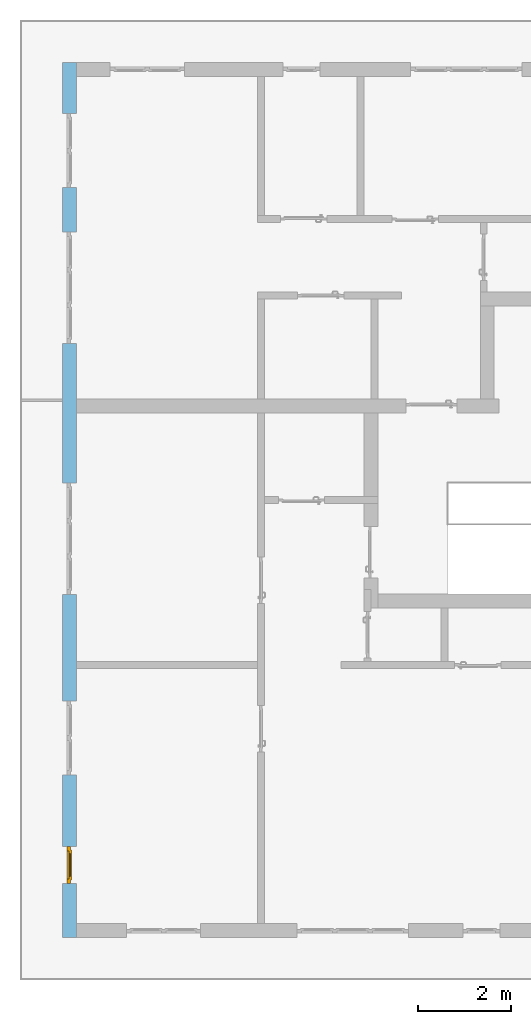
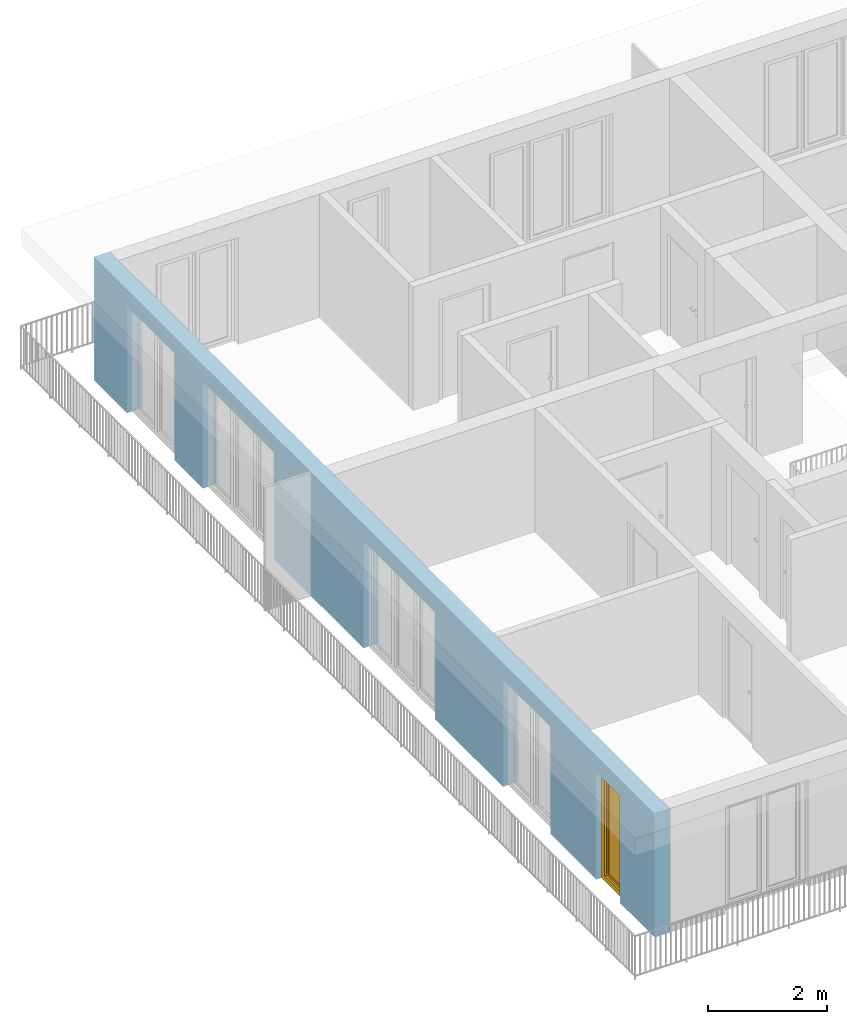
# One storey, part 12 of 54: 1 window, 5 openings, plus 1 element that does not belong to this part.
"""IFC4 building model written with IfcOpenShell, lengths in metres."""

import ifcopenshell
import ifcopenshell.guid

model = None  # the IFC model being written
_history = None  # IfcOwnerHistory: only IFC2X3 demands one
_inside = {}  # id of a spatial element -> (the spatial element, [elements in it])
_under = {}  # id of a project, library or spatial element -> (it, [spatial elements below it])
_declared = {}  # id of a project -> (the project, [libraries it declares])
_typed = {}  # id of a type object -> (the type object, [elements of that type])
_made_of = {}  # id of a material, layer set ... -> (it, [elements and type objects made of it])


def new_model(schema):
    """Start an empty IFC model of exactly this schema.

    Asked for "IFC4X3", IfcOpenShell would pick the latest addendum, in which some entities
    have other attributes; the version numbers below select the first issue.
    IFC2X3 requires an IfcOwnerHistory on every rooted entity: one is made here for all.
    """
    global model, _history
    if schema == "IFC4X3":
        model = ifcopenshell.file(schema_version=(4, 3, 0, 0))
    else:
        model = ifcopenshell.file(schema=schema)
    _inside.clear()
    _under.clear()
    _declared.clear()
    _typed.clear()
    _made_of.clear()
    _history = None
    if model.schema == "IFC2X3":
        org = make("IfcOrganization", Name="unknown")
        user = make(
            "IfcPersonAndOrganization",
            ThePerson=make("IfcPerson", FamilyName="unknown"),
            TheOrganization=org,
        )
        app = make(
            "IfcApplication",
            ApplicationDeveloper=org,
            Version="unknown",
            ApplicationFullName="unknown",
            ApplicationIdentifier="unknown",
        )
        _history = make(
            "IfcOwnerHistory",
            OwningUser=user,
            OwningApplication=app,
            ChangeAction="ADDED",
            CreationDate=0,
        )
    return model


def make(cls, **values):
    """One entity of the class cls with the attributes given. An attribute that is None is left unset."""
    return model.create_entity(
        cls, **{name: value for name, value in values.items() if value is not None}
    )


def entity(cls, *values):
    """Any entity or typed value of the class cls, its attributes in the order of the schema. None: left unset."""
    e = model.create_entity(cls)
    for i, value in enumerate(values):
        if value is not None:
            e[i] = value
    return e


def rooted(cls, **values):
    """An entity with a GlobalId (a new one), such as an element, a storey or a relation."""
    return make(cls, GlobalId=ifcopenshell.guid.new(), OwnerHistory=_history, **values)


def si_unit(unit_type, name, prefix=None):
    """IfcSIUnit, for example si_unit("LENGTHUNIT", "METRE", prefix="MILLI")."""
    return make("IfcSIUnit", UnitType=unit_type, Prefix=prefix, Name=name)


def converted_unit(unit_type, name, factor, base, dimensions=None, offset=None):
    """IfcConversionBasedUnit, such as the inch: factor (a typed value) times the base unit."""
    return make(
        "IfcConversionBasedUnit"
        if offset is None
        else "IfcConversionBasedUnitWithOffset",
        ConversionOffset=offset,
        Dimensions=None
        if dimensions is None
        else entity("IfcDimensionalExponents", *dimensions),
        UnitType=unit_type,
        Name=name,
        ConversionFactor=make(
            "IfcMeasureWithUnit", ValueComponent=factor, UnitComponent=base
        ),
    )


def derived_unit(unit_type, elements):
    """IfcDerivedUnit: a product of units, each with its exponent."""
    return make(
        "IfcDerivedUnit",
        Elements=[
            make("IfcDerivedUnitElement", Unit=unit, Exponent=power)
            for unit, power in elements
        ],
        UnitType=unit_type,
    )


def assignment(units):
    """IfcUnitAssignment: the units of a project."""
    return None if units is None else make("IfcUnitAssignment", Units=units)


def point(xyz):
    """IfcCartesianPoint."""
    return None if xyz is None else make("IfcCartesianPoint", Coordinates=xyz)


def direction(xyz):
    """IfcDirection."""
    return None if xyz is None else make("IfcDirection", DirectionRatios=xyz)


def frame(location, z_axis=None, x_axis=None):
    """IfcAxis2Placement3D, a coordinate frame: its origin and axes. An axis left out is left unset."""
    return make(
        "IfcAxis2Placement3D",
        Location=point(location),
        Axis=direction(z_axis),
        RefDirection=direction(x_axis),
    )


def origin_with_axes():
    """The frame at (0, 0, 0) with the z axis (0, 0, 1) and the x axis (1, 0, 0) written out."""
    return frame((0.0, 0.0, 0.0), z_axis=(0.0, 0.0, 1.0), x_axis=(1.0, 0.0, 0.0))


def place(relative_to, where):
    """IfcLocalPlacement: puts the frame where relative to a parent placement (None: the world)."""
    return make(
        "IfcLocalPlacement", PlacementRelTo=relative_to, RelativePlacement=where
    )


def context(
    kind, dimensions, precision=None, world=None, true_north=None, identifier=None
):
    """IfcGeometricRepresentationContext, for example the 3D "Model" context."""
    return make(
        "IfcGeometricRepresentationContext",
        ContextIdentifier=identifier,
        ContextType=kind,
        CoordinateSpaceDimension=dimensions,
        Precision=precision,
        WorldCoordinateSystem=world,
        TrueNorth=true_north,
    )


def subcontext(parent, identifier, kind, view, scale=None):
    """IfcGeometricRepresentationSubContext, for example "Body" below "Model"."""
    return make(
        "IfcGeometricRepresentationSubContext",
        ContextIdentifier=identifier,
        ContextType=kind,
        ParentContext=parent,
        TargetScale=scale,
        TargetView=view,
    )


def project(units=None, contexts=None):
    """IfcProject with its units and contexts."""
    return rooted(
        "IfcProject",
        Name="project",
        RepresentationContexts=contexts,
        UnitsInContext=assignment(units),
    )


def spatial(cls, under=None, at=None, **own):
    """A site, building, storey or space (cls), placed at a placement, below another one or the project."""
    s = rooted(cls, ObjectPlacement=at, **own)
    if under is not None:
        _under.setdefault(under.id(), (under, []))[1].append(s)
    return s


def point_list(points):
    """IfcCartesianPointList2D or 3D."""
    cls = (
        "IfcCartesianPointList2D" if len(points[0]) == 2 else "IfcCartesianPointList3D"
    )
    return make(cls, CoordList=points)


def polygons(points, faces, closed=None, point_numbers=None):
    """IfcPolygonalFaceSet: a face is its outer loop, then its inner loops; points numbered from 1."""
    made = []
    for loops in faces:
        if len(loops) == 1:
            made.append(make("IfcIndexedPolygonalFace", CoordIndex=loops[0]))
        else:
            made.append(
                make(
                    "IfcIndexedPolygonalFaceWithVoids",
                    CoordIndex=loops[0],
                    InnerCoordIndices=loops[1:],
                )
            )
    return make(
        "IfcPolygonalFaceSet",
        Coordinates=point_list(points),
        Closed=closed,
        Faces=made,
        PnIndex=point_numbers,
    )


def shape(context_of_items, identifier, shape_type, items):
    """IfcShapeRepresentation: the items that make up one representation, for example the "Body"."""
    return make(
        "IfcShapeRepresentation",
        ContextOfItems=context_of_items,
        RepresentationIdentifier=identifier,
        RepresentationType=shape_type,
        Items=items,
    )


def source(mapping_origin, context_of_items, identifier, shape_type, items):
    """IfcRepresentationMap: a shape defined once, which mapped items show again and again."""
    return make(
        "IfcRepresentationMap",
        MappingOrigin=mapping_origin,
        MappedRepresentation=shape(context_of_items, identifier, shape_type, items),
    )


def transform(
    local_origin,
    x_axis=None,
    y_axis=None,
    z_axis=None,
    scale=None,
    scale2=None,
    scale3=None,
    uniform=True,
):
    """IfcCartesianTransformationOperator3D, or its non-uniform kind. x_axis, y_axis, z_axis: its Axis1, 2, 3."""
    if uniform:
        return make(
            "IfcCartesianTransformationOperator3D",
            Axis1=direction(x_axis),
            Axis2=direction(y_axis),
            LocalOrigin=point(local_origin),
            Scale=scale,
            Axis3=direction(z_axis),
        )
    return make(
        "IfcCartesianTransformationOperator3DnonUniform",
        Axis1=direction(x_axis),
        Axis2=direction(y_axis),
        LocalOrigin=point(local_origin),
        Scale=scale,
        Axis3=direction(z_axis),
        Scale2=scale2,
        Scale3=scale3,
    )


def mapped(mapping_source, mapping_target):
    """IfcMappedItem: shows the shape of a source again, moved by a transform."""
    return make(
        "IfcMappedItem", MappingSource=mapping_source, MappingTarget=mapping_target
    )


def material(Name=None, Category=None):
    """IfcMaterial."""
    return make("IfcMaterial", Name=Name, Category=Category)


def made_of(thing, what):
    """Note that an element or type object is made of a material, layer set ...; save() writes the relation."""
    if what is not None:
        _made_of.setdefault(what.id(), (what, []))[1].append(thing)
    return thing


def type_object(cls, material=None, **own):
    """A type object (cls), such as IfcWallType, which elements share."""
    return made_of(rooted(cls, **own), material)


def element(
    cls,
    number,
    at=None,
    inside=None,
    cuts=None,
    type_object=None,
    material=None,
    context=None,
    identifier="Body",
    shape_type=None,
    held_by="IfcProductDefinitionShape",
    body=None,
    shapes=None,
    **own,
):
    """One element of the class cls, such as IfcWall. Its Tag is "e" and its number.

    at: its placement. inside: the storey or other place that contains it. cuts: it is an
    opening in that element (IfcRelVoidsElement). A single representation is given by context,
    identifier, shape_type and body (its items); several are given by shapes. held_by: the class
    of the entity that holds the representations. save() writes the other relations.
    """
    e = rooted(cls, Tag="e%d" % number, ObjectPlacement=at, **own)
    if body is not None:
        shapes = [shape(context, identifier, shape_type, body)]
    if shapes is not None:
        e.Representation = make(held_by, Representations=shapes)
    if inside is not None:
        _inside.setdefault(inside.id(), (inside, []))[1].append(e)
    if cuts is not None:
        rooted(
            "IfcRelVoidsElement", RelatingBuildingElement=cuts, RelatedOpeningElement=e
        )
    if type_object is not None:
        _typed.setdefault(type_object.id(), (type_object, []))[1].append(e)
    return made_of(e, material)


def fill(opening, filler):
    """IfcRelFillsElement: the door or window that sits in an opening."""
    return rooted(
        "IfcRelFillsElement",
        RelatingOpeningElement=opening,
        RelatedBuildingElement=filler,
    )


def aggregate(whole, parts):
    """IfcRelAggregates: a whole, such as a stair, and the parts it consists of."""
    return rooted("IfcRelAggregates", RelatingObject=whole, RelatedObjects=parts)


def save(model, path):
    """Write the relations noted so far, then the file.

    IfcRelAggregates (storeys below a building ...), IfcRelContainedInSpatialStructure (elements
    in a storey), IfcRelDefinesByType, IfcRelAssociatesMaterial and IfcRelDeclares: one each for
    every whole, place, type object, material and project.
    """
    for whole, parts in _under.values():
        aggregate(whole, parts)
    for where, things in _inside.values():
        rooted(
            "IfcRelContainedInSpatialStructure",
            RelatedElements=things,
            RelatingStructure=where,
        )
    for kind, things in _typed.values():
        rooted("IfcRelDefinesByType", RelatedObjects=things, RelatingType=kind)
    for what, things in _made_of.values():
        rooted("IfcRelAssociatesMaterial", RelatedObjects=things, RelatingMaterial=what)
    for by, libraries in _declared.values():
        rooted("IfcRelDeclares", RelatingContext=by, RelatedDefinitions=libraries)
    model.write(path)


model = new_model("IFC4")

# Units and contexts
model_context = context("Model", 3, precision=1e-05, world=origin_with_axes(), true_north=direction((0.0, 1.0)))
body_context = subcontext(model_context, "Body", "Model", "MODEL_VIEW")
ifc_project = project(units=[si_unit("LENGTHUNIT", "METRE"), si_unit("AREAUNIT", "SQUARE_METRE"), si_unit("VOLUMEUNIT", "CUBIC_METRE"), converted_unit("PLANEANGLEUNIT", "DEGREE", entity("IfcPlaneAngleMeasure", 0.0174532925199), si_unit("PLANEANGLEUNIT", "RADIAN"), dimensions=[0, 0, 0, 0, 0, 0, 0]), converted_unit("TIMEUNIT", "Year", entity("IfcTimeMeasure", 31556926.0), si_unit("TIMEUNIT", "SECOND"), dimensions=[0, 0, 1, 0, 0, 0, 0]), si_unit("MASSUNIT", "GRAM", prefix="KILO"), si_unit("THERMODYNAMICTEMPERATUREUNIT", "DEGREE_CELSIUS"), si_unit("LUMINOUSINTENSITYUNIT", "LUMEN"), si_unit("ENERGYUNIT", "JOULE", prefix="MEGA"), derived_unit("THERMALCONDUCTANCEUNIT", [(si_unit("POWERUNIT", "WATT"), 1), (si_unit("LENGTHUNIT", "METRE"), -1), (si_unit("THERMODYNAMICTEMPERATUREUNIT", "KELVIN"), -1)]), derived_unit("SPECIFICHEATCAPACITYUNIT", [(si_unit("ENERGYUNIT", "JOULE"), 1), (si_unit("MASSUNIT", "GRAM", prefix="KILO"), -1), (si_unit("THERMODYNAMICTEMPERATUREUNIT", "KELVIN"), -1)]), derived_unit("MASSDENSITYUNIT", [(si_unit("MASSUNIT", "GRAM", prefix="KILO"), 1), (si_unit("VOLUMEUNIT", "CUBIC_METRE"), -1)])], contexts=[model_context])

# Site, building, storey
site_placement = place(None, origin_with_axes())
site = spatial("IfcSite", under=ifc_project, at=site_placement, CompositionType="ELEMENT")
building_placement = place(site_placement, origin_with_axes())
building = spatial("IfcBuilding", under=site, at=building_placement, CompositionType="ELEMENT")
storey_placement = place(building_placement, frame((0.0, 0.0, 6.29), z_axis=(0.0, 0.0, 1.0), x_axis=(1.0, 0.0, 0.0)))
storey = spatial("IfcBuildingStorey", under=building, at=storey_placement, Name="2. Geschoss", CompositionType="ELEMENT", Elevation=6.29)

# Wall, openings, window
ifc_material = material()
wall_type = type_object("IfcWallType", Name="300", PredefinedType="NOTDEFINED")
wall_placement = place(storey_placement, frame((-11.7421993804, -9.92881223104, 0.0), z_axis=(0.0, 0.0, 1.0), x_axis=(0.0, 1.0, 0.0)))
wall = element("IfcWall", 1, at=wall_placement, inside=storey, type_object=wall_type, material=ifc_material, Name="Wand-001", PredefinedType="NOTDEFINED", context=body_context, shape_type="Tessellation", body=[
    polygons([(1.16441876325, -0.3, 0.0), (1.16441876325, -0.3, 2.2), (1.96441876325, -0.3, 2.2), (1.96441876325, -0.3, 0.0), (3.5, -0.3, 0.0), (3.5, -0.3, 2.2), (5.1, -0.3, 2.2), (5.1, -0.3, 0.0), (7.3921181063, -0.3, 0.0), (7.3921181063, -0.3, 2.2), (9.7921181063, -0.3, 2.2), (9.7921181063, -0.3, 0.0), (12.8, -0.3, 0.0), (12.8, -0.3, 2.2), (15.2, -0.3, 2.2), (15.2, -0.3, 0.0), (16.15, -0.3, 0.0), (16.15, -0.3, 2.2), (17.75, -0.3, 2.2), (17.75, -0.3, 0.0), (18.85, -0.3, 0.0), (18.85, -0.3, 2.54), (0.0, -0.3, 2.54), (0.0, -0.3, 0.0), (1.16441876325, -0.1, 0.0), (1.16441876325, -0.1, 2.2), (1.96441876325, -0.1, 2.2), (1.96441876325, -0.1, 0.0), (1.96441876325, 0.0, 0.0), (3.5, 0.0, 0.0), (3.5, -0.1, 0.0), (3.5, -0.1, 2.2), (5.1, -0.1, 2.2), (5.1, -0.1, 0.0), (5.1, 0.0, 0.0), (7.3921181063, 0.0, 0.0), (7.3921181063, -0.1, 0.0), (7.3921181063, -0.1, 2.2), (9.7921181063, -0.1, 2.2), (9.7921181063, -0.1, 0.0), (9.7921181063, 0.0, 0.0), (12.8, 0.0, 0.0), (12.8, -0.1, 0.0), (12.8, -0.1, 2.2), (15.2, -0.1, 2.2), (15.2, -0.1, 0.0), (15.2, 0.0, 0.0), (16.15, 0.0, 0.0), (16.15, -0.1, 0.0), (16.15, -0.1, 2.2), (17.75, -0.1, 2.2), (17.75, -0.1, 0.0), (17.75, 0.0, 0.0), (18.85, 0.0, 0.0), (18.85, 0.0, 2.54), (0.0, 0.0, 2.54), (0.0, 0.0, 0.0), (1.16441876325, 0.0, 0.0), (1.16441876325, 0.0, 2.2), (1.96441876325, 0.0, 2.2), (17.75, 0.0, 2.2), (16.15, 0.0, 2.2), (15.2, 0.0, 2.2), (12.8, 0.0, 2.2), (9.7921181063, 0.0, 2.2), (7.3921181063, 0.0, 2.2), (5.1, 0.0, 2.2), (3.5, 0.0, 2.2)], [[[1, 2, 3, 4, 5, 6, 7, 8, 9, 10, 11, 12, 13, 14, 15, 16, 17, 18, 19, 20, 21, 22, 23, 24]], [[2, 1, 25, 26]], [[3, 2, 26, 27]], [[4, 3, 27, 28]], [[4, 28, 29, 30, 31, 5]], [[31, 32, 6, 5]], [[32, 33, 7, 6]], [[33, 34, 8, 7]], [[8, 34, 35, 36, 37, 9]], [[10, 9, 37, 38]], [[11, 10, 38, 39]], [[12, 11, 39, 40]], [[12, 40, 41, 42, 43, 13]], [[43, 44, 14, 13]], [[44, 45, 15, 14]], [[45, 46, 16, 15]], [[16, 46, 47, 48, 49, 17]], [[18, 17, 49, 50]], [[19, 18, 50, 51]], [[20, 19, 51, 52]], [[52, 53, 54, 21, 20]], [[22, 21, 54, 55]], [[22, 55, 56, 23]], [[56, 57, 24, 23]], [[25, 1, 24, 57, 58]], [[26, 25, 58, 59]], [[27, 26, 59, 60]], [[28, 27, 60, 29]], [[30, 29, 60, 59, 58, 57, 56, 55, 54, 53, 61, 62, 48, 47, 63, 64, 42, 41, 65, 66, 36, 35, 67, 68]], [[30, 68, 32, 31]], [[68, 67, 33, 32]], [[67, 35, 34, 33]], [[38, 37, 36, 66]], [[39, 38, 66, 65]], [[40, 39, 65, 41]], [[42, 64, 44, 43]], [[64, 63, 45, 44]], [[63, 47, 46, 45]], [[50, 49, 48, 62]], [[51, 50, 62, 61]], [[52, 51, 61, 53]]], closed=True),
])
opening_1_placement = place(wall_placement, frame((16.95, 0.0, 0.0), z_axis=(0.0, 0.0, 1.0), x_axis=(1.0, 0.0, 0.0)))
element("IfcOpeningElement", 2, at=opening_1_placement, cuts=wall, Name="Fenster-001", context=body_context, identifier="Reference", shape_type="Tessellation", body=[
    polygons([(-0.8, -0.1, 0.0), (-0.8, -0.1, 2.2), (-0.8, 0.000999999999999, 2.2), (-0.8, 0.000999999999999, 0.0), (-0.8, -0.301, 0.0), (-0.8, -0.301, 2.2), (0.8, -0.1, 2.2), (0.8, 0.000999999999999, 2.2), (0.8, -0.301, 2.2), (0.8, 0.000999999999999, 0.0), (0.8, -0.1, 0.0), (0.8, -0.301, 0.0)], [[[1, 2, 3, 4]], [[2, 1, 5, 6]], [[7, 8, 3, 2, 6, 9]], [[8, 10, 4, 3]], [[1, 4, 10, 11, 12, 5]], [[6, 5, 12, 9]], [[7, 11, 10, 8]], [[11, 7, 9, 12]]], closed=True),
])
opening_2_placement = place(wall_placement, frame((14.0, 0.0, 0.0), z_axis=(0.0, 0.0, 1.0), x_axis=(1.0, 0.0, 0.0)))
element("IfcOpeningElement", 3, at=opening_2_placement, cuts=wall, Name="Fenster-002", context=body_context, identifier="Reference", shape_type="Tessellation", body=[
    polygons([(-1.2, -0.1, 0.0), (-1.2, -0.1, 2.2), (-1.2, 0.000999999999999, 2.2), (-1.2, 0.000999999999999, 0.0), (-1.2, -0.301, 0.0), (-1.2, -0.301, 2.2), (1.2, -0.1, 2.2), (1.2, 0.000999999999999, 2.2), (1.2, -0.301, 2.2), (1.2, 0.000999999999999, 0.0), (1.2, -0.1, 0.0), (1.2, -0.301, 0.0)], [[[1, 2, 3, 4]], [[2, 1, 5, 6]], [[7, 8, 3, 2, 6, 9]], [[8, 10, 4, 3]], [[1, 4, 10, 11, 12, 5]], [[6, 5, 12, 9]], [[7, 11, 10, 8]], [[11, 7, 9, 12]]], closed=True),
])
opening_3_placement = place(wall_placement, frame((8.5921181063, 0.0, 0.0), z_axis=(0.0, 0.0, 1.0), x_axis=(1.0, 0.0, 0.0)))
element("IfcOpeningElement", 4, at=opening_3_placement, cuts=wall, Name="Fenster-002", context=body_context, identifier="Reference", shape_type="Tessellation", body=[
    polygons([(-1.2, -0.1, 0.0), (-1.2, -0.1, 2.2), (-1.2, 0.000999999999999, 2.2), (-1.2, 0.000999999999999, 0.0), (-1.2, -0.301, 0.0), (-1.2, -0.301, 2.2), (1.2, -0.1, 2.2), (1.2, 0.000999999999999, 2.2), (1.2, -0.301, 2.2), (1.2, 0.000999999999999, 0.0), (1.2, -0.1, 0.0), (1.2, -0.301, 0.0)], [[[1, 2, 3, 4]], [[2, 1, 5, 6]], [[7, 8, 3, 2, 6, 9]], [[8, 10, 4, 3]], [[1, 4, 10, 11, 12, 5]], [[6, 5, 12, 9]], [[7, 11, 10, 8]], [[11, 7, 9, 12]]], closed=True),
])
opening_4_placement = place(wall_placement, frame((4.3, 0.0, 0.0), z_axis=(0.0, 0.0, 1.0), x_axis=(1.0, 0.0, 0.0)))
element("IfcOpeningElement", 5, at=opening_4_placement, cuts=wall, Name="Fenster-001", context=body_context, identifier="Reference", shape_type="Tessellation", body=[
    polygons([(-0.8, -0.1, 0.0), (-0.8, -0.1, 2.2), (-0.8, 0.000999999999999, 2.2), (-0.8, 0.000999999999999, 0.0), (-0.8, -0.301, 0.0), (-0.8, -0.301, 2.2), (0.8, -0.1, 2.2), (0.8, 0.000999999999999, 2.2), (0.8, -0.301, 2.2), (0.8, 0.000999999999999, 0.0), (0.8, -0.1, 0.0), (0.8, -0.301, 0.0)], [[[1, 2, 3, 4]], [[2, 1, 5, 6]], [[7, 8, 3, 2, 6, 9]], [[8, 10, 4, 3]], [[1, 4, 10, 11, 12, 5]], [[6, 5, 12, 9]], [[7, 11, 10, 8]], [[11, 7, 9, 12]]], closed=True),
])
opening_5_placement = place(wall_placement, frame((1.56441876325, 0.0, 0.0), z_axis=(0.0, 0.0, 1.0), x_axis=(1.0, 0.0, 0.0)))
opening_5 = element("IfcOpeningElement", 6, at=opening_5_placement, cuts=wall, Name="Fenster-003", context=body_context, identifier="Reference", shape_type="Tessellation", body=[
    polygons([(-0.4, -0.1, 0.0), (-0.4, -0.1, 2.2), (-0.4, 0.000999999999999, 2.2), (-0.4, 0.000999999999999, 0.0), (-0.4, -0.301, 0.0), (-0.4, -0.301, 2.2), (0.4, -0.1, 2.2), (0.4, 0.000999999999999, 2.2), (0.4, -0.301, 2.2), (0.4, 0.000999999999999, 0.0), (0.4, -0.1, 0.0), (0.4, -0.301, 0.0)], [[[1, 2, 3, 4]], [[2, 1, 5, 6]], [[7, 8, 3, 2, 6, 9]], [[8, 10, 4, 3]], [[1, 4, 10, 11, 12, 5]], [[6, 5, 12, 9]], [[7, 11, 10, 8]], [[11, 7, 9, 12]]], closed=True),
])
window_type = type_object("IfcWindowType", Name="1-26", PartitioningType="SINGLE_PANEL", PredefinedType="WINDOW")
shared_shape = source(origin_with_axes(), body_context, "Body", "Tessellation", [
    polygons([(-0.4, -0.07, 0.0), (-0.4, 0.0, 0.0), (-0.3, 0.0, 0.1), (-0.3, -0.07, 0.1), (-0.4, -0.07, 2.2), (-0.4, 0.0, 2.2), (-0.3, 0.0, 2.1), (-0.3, -0.07, 2.1)], [[[1, 2, 3, 4]], [[5, 6, 2, 1]], [[2, 6, 7, 3]], [[4, 3, 7, 8]], [[1, 4, 8, 5]], [[8, 7, 6, 5]]], closed=True),
    polygons([(0.4, -0.07, 0.0), (0.4, 0.0, 0.0), (0.4, 0.0, 2.2), (0.4, -0.07, 2.2), (0.3, -0.07, 0.1), (0.3, 0.0, 0.1), (0.3, 0.0, 2.1), (0.3, -0.07, 2.1)], [[[1, 2, 3, 4]], [[5, 6, 2, 1]], [[2, 6, 7, 3]], [[4, 3, 7, 8]], [[1, 4, 8, 5]], [[8, 7, 6, 5]]], closed=True),
    polygons([(-0.4, -0.07, 0.0), (-0.4, 0.0, 0.0), (0.4, 0.0, 0.0), (0.4, -0.07, 0.0), (-0.3, -0.07, 0.1), (-0.3, 0.0, 0.1), (0.0, 0.0, 0.1), (0.3, 0.0, 0.1), (0.3, -0.07, 0.1), (0.0, -0.07, 0.1)], [[[1, 2, 3, 4]], [[5, 6, 2, 1]], [[2, 6, 7, 8, 3]], [[4, 3, 8, 9]], [[1, 4, 9, 10, 5]], [[10, 7, 6, 5]], [[9, 8, 7, 10]]], closed=True),
    polygons([(-0.4, -0.07, 2.2), (-0.4, 0.0, 2.2), (-0.3, 0.0, 2.1), (-0.3, -0.07, 2.1), (0.4, -0.07, 2.2), (0.4, 0.0, 2.2), (0.3, 0.0, 2.1), (0.0, 0.0, 2.1), (0.0, -0.07, 2.1), (0.3, -0.07, 2.1)], [[[1, 2, 3, 4]], [[5, 6, 2, 1]], [[2, 6, 7, 8, 3]], [[4, 3, 8, 9]], [[1, 4, 9, 10, 5]], [[10, 7, 6, 5]], [[9, 8, 7, 10]]], closed=True),
    polygons([(-0.32, 0.0, 0.08), (-0.32, 0.03, 0.08), (-0.25, 0.03, 0.15), (-0.25, 0.0, 0.15), (-0.32, 0.0, 2.12), (-0.32, 0.03, 2.12), (-0.25, 0.03, 2.05), (-0.25, 0.0, 2.05)], [[[1, 2, 3, 4]], [[5, 6, 2, 1]], [[2, 6, 7, 3]], [[4, 3, 7, 8]], [[1, 4, 8, 5]], [[8, 7, 6, 5]]], closed=True),
    polygons([(0.32, 0.0, 0.08), (0.25, 0.0, 0.15), (0.25, 0.03, 0.15), (0.32, 0.03, 0.08), (0.32, 0.0, 2.12), (0.25, 0.0, 2.05), (0.25, 0.03, 2.05), (0.32, 0.03, 2.12)], [[[1, 2, 3, 4]], [[1, 5, 6, 2]], [[2, 6, 7, 3]], [[4, 3, 7, 8]], [[5, 1, 4, 8]], [[6, 5, 8, 7]]], closed=True),
    polygons([(-0.32, 0.0, 0.08), (-0.32, 0.03, 0.08), (0.32, 0.03, 0.08), (0.32, 0.0, 0.08), (-0.25, 0.0, 0.15), (-0.25, 0.03, 0.15), (0.25, 0.03, 0.15), (0.25, 0.0, 0.15)], [[[1, 2, 3, 4]], [[5, 6, 2, 1]], [[2, 6, 7, 3]], [[4, 3, 7, 8]], [[1, 4, 8, 5]], [[8, 7, 6, 5]]], closed=True),
    polygons([(-0.32, 0.0, 2.12), (0.32, 0.0, 2.12), (0.32, 0.03, 2.12), (-0.32, 0.03, 2.12), (-0.25, 0.0, 2.05), (0.25, 0.0, 2.05), (0.25, 0.03, 2.05), (-0.25, 0.03, 2.05)], [[[1, 2, 3, 4]], [[1, 5, 6, 2]], [[2, 6, 7, 3]], [[4, 3, 7, 8]], [[5, 1, 4, 8]], [[6, 5, 8, 7]]], closed=True),
    polygons([(-0.3, -0.03, 0.1), (-0.3, 0.0, 0.1), (-0.25, 0.0, 0.15), (-0.25, -0.03, 0.15), (-0.3, -0.03, 2.1), (-0.3, 0.0, 2.1), (-0.25, 0.0, 2.05), (-0.25, -0.03, 2.05)], [[[1, 2, 3, 4]], [[5, 6, 2, 1]], [[2, 6, 7, 3]], [[4, 3, 7, 8]], [[1, 4, 8, 5]], [[8, 7, 6, 5]]], closed=True),
    polygons([(0.3, -0.03, 0.1), (0.25, -0.03, 0.15), (0.25, 0.0, 0.15), (0.3, 0.0, 0.1), (0.3, -0.03, 2.1), (0.25, -0.03, 2.05), (0.25, 0.0, 2.05), (0.3, 0.0, 2.1)], [[[1, 2, 3, 4]], [[1, 5, 6, 2]], [[2, 6, 7, 3]], [[4, 3, 7, 8]], [[5, 1, 4, 8]], [[6, 5, 8, 7]]], closed=True),
    polygons([(-0.3, -0.03, 0.1), (-0.3, 0.0, 0.1), (0.3, 0.0, 0.1), (0.3, -0.03, 0.1), (-0.25, -0.03, 0.15), (-0.25, 0.0, 0.15), (0.25, 0.0, 0.15), (0.25, -0.03, 0.15)], [[[1, 2, 3, 4]], [[5, 6, 2, 1]], [[2, 6, 7, 3]], [[4, 3, 7, 8]], [[1, 4, 8, 5]], [[8, 7, 6, 5]]], closed=True),
    polygons([(-0.3, -0.03, 2.1), (0.3, -0.03, 2.1), (0.3, 0.0, 2.1), (-0.3, 0.0, 2.1), (-0.25, -0.03, 2.05), (0.25, -0.03, 2.05), (0.25, 0.0, 2.05), (-0.25, 0.0, 2.05)], [[[1, 2, 3, 4]], [[1, 5, 6, 2]], [[2, 6, 7, 3]], [[4, 3, 7, 8]], [[5, 1, 4, 8]], [[6, 5, 8, 7]]], closed=True),
    polygons([(-0.25, -0.005, 0.15), (-0.25, 0.005, 0.15), (0.25, 0.005, 0.15), (0.25, -0.005, 0.15), (-0.25, -0.005, 2.05), (-0.25, 0.005, 2.05), (0.25, 0.005, 2.05), (0.25, -0.005, 2.05)], [[[1, 2, 3, 4]], [[5, 6, 2, 1]], [[2, 6, 7, 3]], [[4, 3, 7, 8]], [[1, 4, 8, 5]], [[8, 7, 6, 5]]], closed=True),
])
window_placement = place(opening_5_placement, frame((0.4, 0.0, 0.0), z_axis=(0.0, 0.0, 1.0), x_axis=(-1.0, 0.0, 0.0)))
window = element("IfcWindow", 7, at=window_placement, inside=storey, type_object=window_type, Name="Fenster-003", OverallHeight=2.2, OverallWidth=0.8, PredefinedType="WINDOW", context=body_context, shape_type="MappedRepresentation", body=[
    mapped(shared_shape, transform((0.4, 0.17, 0.0))),
])
fill(opening_5, window)

save(model, "model.ifc")
